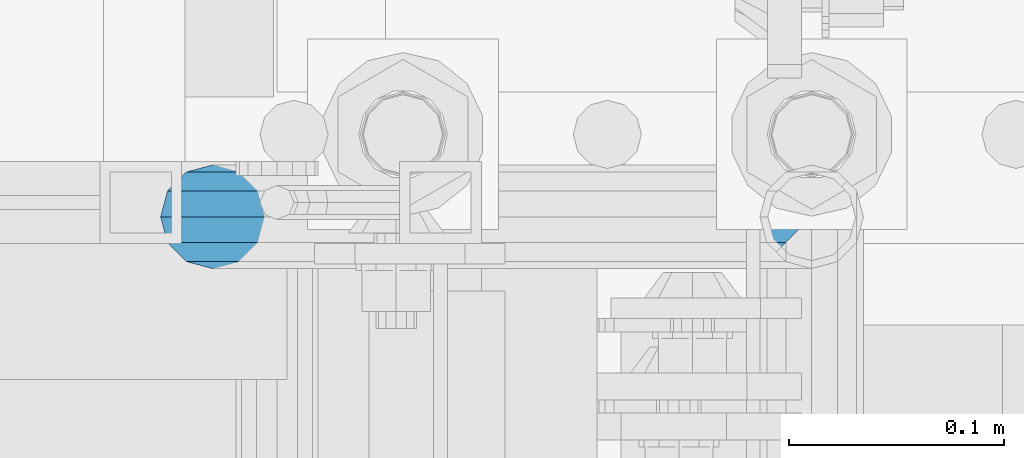
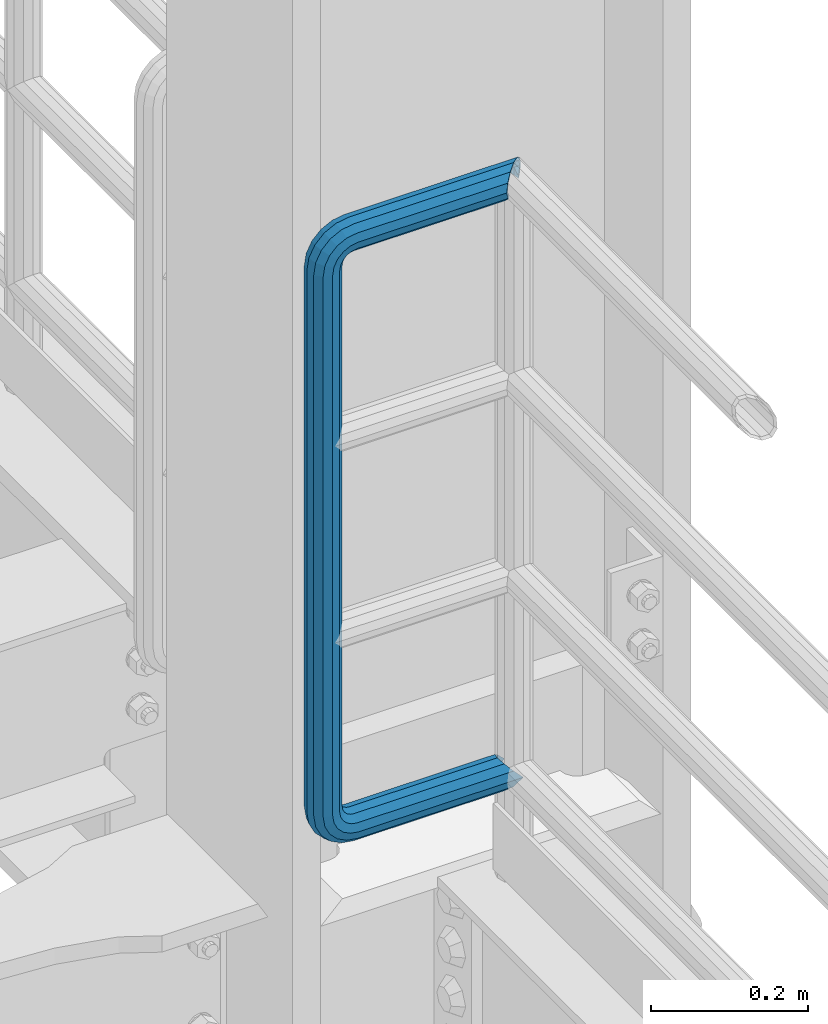
# One storey, part 992 of 1876: 1 beam, 1 element without a shape of its own.
"""IFC2X3 building model written with IfcOpenShell, lengths in millimetres."""

from ifc_helpers import new_model, si_unit, frame, origin_with_axes, place, context, subcontext, project, spatial, faceted_brep, material, type_object, element, aggregate, save


model = new_model("IFC2X3")

# Units and contexts
model_context = context("Model", 3, precision=1e-05, world=origin_with_axes())
body_context = subcontext(model_context, "Body", "Model", "MODEL_VIEW")
ifc_project = project(units=[si_unit("LENGTHUNIT", "METRE", prefix="MILLI"), si_unit("AREAUNIT", "SQUARE_METRE"), si_unit("VOLUMEUNIT", "CUBIC_METRE"), si_unit("MASSUNIT", "GRAM", prefix="KILO"), si_unit("TIMEUNIT", "SECOND"), si_unit("PLANEANGLEUNIT", "RADIAN"), si_unit("SOLIDANGLEUNIT", "STERADIAN"), si_unit("THERMODYNAMICTEMPERATUREUNIT", "DEGREE_CELSIUS"), si_unit("LUMINOUSINTENSITYUNIT", "LUMEN")], contexts=[model_context])

# Site, building, storey
site_placement = place(None, origin_with_axes())
site = spatial("IfcSite", under=ifc_project, at=site_placement, CompositionType="ELEMENT")
building_placement = place(site_placement, origin_with_axes())
building = spatial("IfcBuilding", under=site, at=building_placement, Name="Undefined", CompositionType="ELEMENT")
storey_placement = place(building_placement, origin_with_axes())
storey = spatial("IfcBuildingStorey", under=building, at=storey_placement, Name="Undefined", CompositionType="ELEMENT", Elevation=0.0)

# Assembly, beam
assembly_placement = place(storey_placement, origin_with_axes())
assembly = element("IfcElementAssembly", 1, at=assembly_placement, inside=storey, Name="RAIL", AssemblyPlace="NOTDEFINED", PredefinedType="RIGID_FRAME")
ifc_material = material()
beam_type = type_object("IfcBeamType", Name="PIPE1-1/2SCH40", PredefinedType="NOTDEFINED")
beam_placement = place(assembly_placement, frame((7620.0, -4788.2175, 19059.525), z_axis=(0.0, 0.0, 1.0), x_axis=(-1.0, 0.0, 0.0)))
beam = element("IfcBeam", 2, at=beam_placement, type_object=beam_type, material=ifc_material, Name="RAIL", ObjectType="PIPE1-1/2SCH40", context=body_context, shape_type="Brep", body=[
    faceted_brep([(16.4810964966631, 16.4810964966564, -11.4500249345219), (16.481099754581, 16.4810997545774, -16.4810932387409), (20.8971929933249, 12.0650000000005, -20.8971929933177), (20.8971929933249, 12.0650000000005, -15.8661214311796), (0.0, -24.1299999999992, 0.0), (12.0650000000014, -20.8971929933186, 0.0), (12.0650000000064, -20.8971929933177, -12.0649999999987), (-12.0650000000096, -20.8971929933177, -12.0649999999987), (-12.0649999999986, -20.8971929933186, 0.0), (-16.481093238739, -16.4810932387427, -16.4810997545756), (-16.4810964966554, -16.4810964966618, -11.4500249345183), (-15.2545715621367, -17.7076214311801, -10.2235000000001), (-12.5151929933171, -20.4470000000001, 0.0), (12.5151929933249, -20.4470000000001, 0.0), (20.8971929933249, -12.0650000000005, -15.8661214311796), (20.8971929933249, -12.0650000000005, -20.8971929933177), (15.2545715621445, -17.7076214311801, -10.2235000000001), (24.1300000000063, 0.0, -20.4470000000001), (24.1300000000063, 0.0, -24.130000000001), (21.3906214311868, -10.2235000000001, -17.7076214311819), (21.3906214311868, 10.2235000000001, -17.7076214311819), (1.20714750983051e-12, 24.1299999999974, -914.399963378906), (12.0650000000014, 20.8971929933159, -926.464963378905), (12.0650000000014, 20.8971929933177, -902.334963378908), (12.0650000000014, -20.8971929933195, -902.334963378908), (12.0650000000014, -20.8971929933195, -926.464963378905), (1.52133659548828e-12, -24.130000000001, -914.399963378906), (20.8971929933199, -12.0650000000023, -893.502770385589), (20.8971929933199, -12.0650000000005, -898.533841947723), (15.2545715621378, -17.7076214311819, -904.176463378906), (12.5151929933181, -20.4470000000019, -914.399963378906), (15.2545715621376, -17.7076214311819, -924.623463378906), (20.8971929933199, -12.0650000000005, -930.26608481009), (20.8971929933199, -12.0650000000023, -935.297156372224), (24.1300000000014, -1.81898940354586e-12, -934.846963378906), (24.1300000000014, -1.81898940354586e-12, -938.529963378907), (21.3906214311813, -10.2235000000019, -932.107584810088), (21.3906214311823, 10.2234999999982, -932.107584810088), (20.8971929933199, 12.0650000000005, -930.266084810086), (20.8971929933199, 12.0649999999987, -935.297156372224), (15.2545715621413, 17.7076214311783, -924.623463378906), (12.5151929933216, 20.4469999999983, -914.399963378906), (15.2545715621411, 17.7076214311783, -904.176463378906), (20.8971929933199, 12.0650000000005, -898.533841947727), (20.8971929933199, 12.0649999999987, -893.502770385589), (21.3906214311822, 10.2234999999982, -896.692341947724), (24.1300000000014, 0.0, -893.952963378906), (24.1300000000014, 0.0, -890.269963378905), (21.3906214311814, -10.2235000000019, -896.692341947724), (241.299995422363, -20.8971929933177, 12.0649999999987), (241.299995422363, -24.1299999999992, 0.0), (253.073542436527, -24.1299999999992, -1.86474665447167), (256.801832473661, -20.8971929933177, 9.60975021462946), (241.299995422363, -12.0650000000005, 20.8971929933177), (259.531130206197, -12.0650000000005, 18.0096649141014), (241.299995422363, 0.0, 24.130000000001), (260.530122510796, 0.0, 21.084247083727), (241.299995422363, 12.0650000000005, 20.8971929933177), (259.531130206197, 12.0650000000005, 18.0096649141014), (241.299995422363, 20.8971929933177, 12.0649999999987), (256.801832473661, 20.8971929933177, 9.60975021462946), (241.299995422363, 24.1299999999992, 0.0), (253.073542436527, 24.1299999999992, -1.86474665447167), (241.299995422363, 20.8971929933177, -12.0649999999987), (249.345252399393, 20.8971929933177, -13.3392435235728), (241.299995422363, 12.0650000000005, -20.8971929933177), (246.615954666858, 12.0650000000005, -21.7391582230448), (241.299995422363, 0.0, -24.130000000001), (245.616962362259, 0.0, -24.8137403926739), (241.299995422363, -12.0650000000005, -20.8971929933177), (246.615954666858, -12.0650000000005, -21.7391582230448), (241.299995422363, -20.8971929933177, -12.0649999999987), (249.345252399393, -20.8971929933177, -13.3392435235728), (267.334993896485, 20.8971929933177, -38.0999984741211), (279.399993896485, 24.1299999999992, -38.0999984741211), (279.399993896484, 24.1299999999992, -876.299964904785), (267.334993896484, 20.8971929933177, -876.299964904785), (291.464993896486, 20.8971929933177, -38.0999984741211), (291.464993896484, 20.8971929933177, -876.299964904785), (300.297186889804, 12.0650000000005, -38.0999984741211), (300.297186889803, 12.0650000000005, -876.299964904785), (303.529993896486, 0.0, -38.0999984741211), (303.529993896484, 0.0, -876.299964904785), (300.297186889804, -12.0650000000005, -38.0999984741211), (300.297186889803, -12.0650000000005, -876.299964904785), (291.464993896486, -20.8971929933177, -38.0999984741211), (291.464993896484, -20.8971929933177, -876.299964904785), (279.399993896484, -24.1299999999992, -38.0999984741211), (279.399993896484, -24.1299999999992, -876.299964904785), (267.334993896485, -20.8971929933177, -38.0999984741211), (267.334993896484, -20.8971929933177, -876.299964904785), (258.502800903167, -12.0650000000005, -38.0999984741211), (258.502800903166, -12.0650000000005, -876.299964904785), (255.269993896485, 0.0, -38.0999984741211), (255.269993896484, 0.0, -876.299964904785), (258.502800903167, 12.0650000000005, -38.0999984741211), (258.502800903166, 12.0650000000005, -876.299964904785), (257.660835673438, 12.0650000000005, -881.615924149282), (254.586253503809, 0.0, -880.616931844681), (257.660835673438, -12.0650000000005, -881.615924149282), (266.06075037291, -20.8971929933177, -884.345221881817), (277.535247242011, -24.130000000001, -888.073511918952), (289.009744111112, -20.8971929933195, -891.801801956084), (297.409658810584, -12.0650000000005, -894.531099688622), (300.484240980214, 0.0, -895.53009199322), (297.409658810584, 12.0650000000005, -894.531099688622), (289.009744111112, 20.8971929933177, -891.801801956084), (277.535247242011, 24.1299999999992, -888.073511918952), (266.06075037291, 20.8971929933177, -884.345221881817), (241.299995422364, -1.81898940354586e-12, -938.529963378911), (241.299995422364, -12.0650000000005, -935.297156372228), (241.299995422364, -20.8971929933195, -926.464963378909), (241.299995422363, -24.130000000001, -914.399963378906), (241.299995422363, -20.8971929933195, -902.334963378908), (241.299995422363, -12.0650000000005, -893.502770385589), (241.299995422363, 0.0, -890.269963378909), (241.299995422364, 20.8971929933177, -926.464963378909), (241.299995422364, 12.0649999999987, -935.297156372228), (241.299995422364, 24.1299999999992, -914.39996337891), (241.299995422363, 20.8971929933177, -902.334963378908), (241.299995422363, 12.0649999999987, -893.502770385589), (260.530122510801, 0.0, -935.484210462637), (259.531130206202, 12.0649999999987, -932.409628293008), (259.531130206201, -12.0650000000005, -932.409628293008), (256.801832473666, -20.8971929933195, -924.009713593536), (253.07354243653, -24.130000000001, -912.535216724435), (249.345252399395, -20.8971929933195, -901.060719855333), (246.615954666859, -12.0650000000005, -892.660805155861), (245.61696236226, 0.0, -889.586222986232), (246.615954666859, 12.0649999999987, -892.660805155861), (249.345252399395, 20.8971929933177, -901.060719855333), (253.07354243653, 24.1299999999992, -912.535216724435), (256.801832473666, 20.8971929933177, -924.009713593536), (275.977674493594, 12.0649999999987, -924.029695422345), (270.786241706733, 20.8971929933177, -916.884301193139), (277.877870775644, 0.0, -926.645091230272), (275.977674493608, -12.0650000000005, -924.029695422334), (270.786241706733, -20.8971929933195, -916.884301193139), (263.694612637823, -24.130000000001, -907.123511156005), (256.602983568912, -20.8971929933195, -897.362721118872), (251.411550782037, -12.0650000000005, -890.21732688968), (249.511354500001, 0.0, -887.601931081743), (251.411550782037, 12.0650000000005, -890.21732688968), (256.602983568912, 20.8971929933177, -897.362721118872), (263.694612637823, 24.1299999999992, -907.123511156005), (281.884331710718, 20.8971929933177, -905.786211189152), (272.123541673585, 24.1299999999992, -898.694582120243), (289.029725939912, 12.0650000000005, -910.977643976028), (291.645121747852, 0.0, -912.877840258065), (289.029725939912, -12.0650000000005, -910.977643976028), (281.884331710718, -20.8971929933195, -905.786211189152), (272.123541673585, -24.130000000001, -898.694582120243), (262.362751636451, -20.8971929933195, -891.602953051333), (255.217357407258, -12.0650000000005, -886.411520264461), (252.601961599318, 0.0, -884.511323982424), (255.217357407258, 12.0650000000005, -886.411520264461), (262.362751636451, 20.8971929933177, -891.602953051333), (266.060750372911, 20.8971929933177, -30.0547414970897), (257.660835673439, 12.0650000000005, -32.7840392296275), (277.535247242011, 24.1299999999992, -26.3264514599541), (289.009744111112, 20.8971929933177, -22.5981614228222), (297.409658810584, 12.0650000000005, -19.8688636902843), (300.484240980213, 0.0, -18.8698713856866), (297.409658810584, -12.0650000000005, -19.8688636902843), (289.009744111112, -20.8971929933177, -22.5981614228222), (277.535247242011, -24.1299999999992, -26.3264514599541), (266.060750372911, -20.8971929933177, -30.0547414970897), (257.660835673439, -12.0650000000005, -32.7840392296275), (254.58625350381, 0.0, -33.7830315342253), (255.217357407257, 12.0650000000005, -27.9884431144455), (252.601961599318, 0.0, -29.8886393964822), (262.362751636451, 20.8971929933177, -22.7970103275729), (272.123541673583, 24.1299999999992, -15.7053812586601), (281.884331710716, 20.8971929933177, -8.61375218975081), (289.029725939909, 12.0650000000005, -3.42231940287456), (291.645121747848, 0.0, -1.52212312084157), (289.029725939909, -12.0650000000005, -3.42231940287456), (281.884331710716, -20.8971929933177, -8.61375218975081), (272.123541673583, -24.1299999999992, -15.7053812586601), (262.362751636451, -20.8971929933177, -22.7970103275729), (255.217357407257, -12.0650000000005, -27.9884431144455), (249.511354500002, 0.0, -26.7980322971671), (251.411550782037, -12.0650000000005, -24.1826364892258), (251.411550782037, 12.0650000000005, -24.1826364892258), (256.602983568912, 20.8971929933177, -17.037242260034), (263.694612637822, 24.1299999999992, -7.27645222290084), (270.786241706732, 20.8971929933177, 2.48433781423228), (275.977674493607, 12.0650000000005, 9.62973204342416), (277.877870775642, 0.0, 12.2451278513654), (275.977674493607, -12.0650000000005, 9.62973204342416), (270.786241706732, -20.8971929933177, 2.48433781423228), (263.694612637822, -24.1299999999992, -7.27645222290084), (256.602983568912, -20.8971929933177, -17.037242260034), (20.8971929933232, 20.8971929933177, -12.0649999999987), (24.1300000000047, 24.1299999999992, 0.0), (20.8971929933232, 20.8971929933177, 12.0649999999987), (12.0650000000041, 12.0650000000005, 20.8971929933177), (-1.45519152283669e-11, 0.0, 24.130000000001), (-12.0649999999951, -12.0650000000005, 20.8971929933177), (-20.8971929933141, -20.8971929933177, 12.0649999999987), (-24.1299999999956, -24.1299999999992, 0.0), (-20.8971929933141, -20.8971929933177, -12.0649999999987), (-17.7076214311755, -17.7076214311801, -10.2235000000001), (-20.4469999999956, -20.4470000000001, 0.0), (-17.7076214311755, -17.7076214311801, 10.2235000000001), (241.299995422363, -17.7076214311801, 10.2235000000001), (241.299995422363, -20.4470000000001, 0.0), (241.299995422363, -17.7076214311801, -10.2235000000001), (241.299995422363, -10.2235000000001, -17.7076214311819), (241.299995422363, 0.0, -20.4470000000001), (241.299995422363, 0.0, 20.4470000000001), (241.299995422363, -10.2235000000001, 17.7076214311819), (-10.2234999999955, -10.2235000000001, 17.7076214311819), (-1.45519152283669e-11, 0.0, 20.4470000000001), (241.299995422363, 10.2235000000001, 17.7076214311819), (10.2235000000046, 10.2235000000001, 17.7076214311819), (241.299995422363, 17.7076214311801, 10.2235000000001), (17.7076214311846, 17.7076214311801, 10.2235000000001), (241.299995422363, 20.4470000000001, 0.0), (20.4470000000047, 20.4470000000001, 0.0), (241.299995422363, 17.7076214311801, -10.2235000000001), (17.7076214311846, 17.7076214311801, -10.2235000000001), (241.299995422363, 10.2235000000001, -17.7076214311819), (258.545498388721, -10.2235000000001, 14.9762020957387), (256.23277767852, -17.7076214311801, 7.85837963987069), (253.073542436527, -20.4470000000001, -1.86474665447167), (249.914307194535, -17.7076214311801, -11.5878729488177), (247.601586484334, -10.2235000000001, -18.7056954046857), (246.755071952542, 0.0, -21.31099924316), (247.601586484334, 10.2235000000001, -18.7056954046857), (249.914307194535, 17.7076214311801, -11.5878729488177), (253.073542436527, 20.4470000000001, -1.86474665447167), (256.23277767852, 17.7076214311801, 7.85837963987069), (258.545498388721, 10.2235000000001, 14.9762020957387), (259.392012920513, 0.0, 17.5815059342131), (275.713057691449, 0.0, 9.26551826108334), (274.10289136825, -10.2235000000001, 7.04931444488102), (274.10289136825, 10.2235000000001, 7.04931444488102), (269.703835164635, 17.7076214311801, 0.994533019089431), (263.694612637822, 20.4470000000001, -7.27645222290084), (257.685390111009, 17.7076214311801, -15.5474374648911), (253.286333907394, 10.2235000000001, -21.6022188906827), (251.676167584195, 0.0, -23.818422706885), (253.286333907394, -10.2235000000001, -21.6022188906827), (257.685390111009, -17.7076214311801, -15.5474374648911), (263.694612637822, -20.4470000000001, -7.27645222290084), (269.703835164635, -17.7076214311801, 0.994533019089431), (286.449308341364, -10.2235000000001, -5.29710252823133), (280.394526915574, -17.7076214311801, -9.69615873184739), (288.665512157566, 0.0, -3.68693620503473), (286.449308341364, 10.2235000000001, -5.29710252823133), (280.394526915574, 17.7076214311801, -9.69615873184739), (272.123541673583, 20.4470000000001, -15.7053812586601), (263.852556431592, 17.7076214311801, -21.7146037854764), (257.797775005802, 10.2235000000001, -26.1136599890888), (255.581571189601, 0.0, -27.723826312289), (257.797775005802, -10.2235000000001, -26.1136599890888), (263.852556431592, -17.7076214311801, -21.7146037854764), (272.123541673583, -20.4470000000001, -15.7053812586601), (287.258373536355, -17.7076214311801, -23.1672162179639), (277.535247242011, -20.4470000000001, -26.3264514599541), (294.376195992223, -10.2235000000001, -20.8544955077632), (296.981499830698, 0.0, -20.00798097597), (294.376195992223, 10.2235000000001, -20.8544955077632), (287.258373536355, 17.7076214311801, -23.1672162179639), (277.535247242011, 20.4470000000001, -26.3264514599541), (267.812120947668, 17.7076214311801, -29.485686701948), (260.6942984918, 10.2235000000001, -31.7984074121487), (258.088994653325, 0.0, -32.6449219439419), (260.6942984918, -10.2235000000001, -31.7984074121487), (267.812120947668, -17.7076214311801, -29.485686701948), (279.399993896484, -20.4470000000001, -38.0999984741211), (269.176493896485, -17.7076214311801, -38.0999984741211), (289.623493896486, -17.7076214311801, -38.0999984741211), (297.107615327666, -10.2235000000001, -38.0999984741211), (299.846993896486, 0.0, -38.0999984741211), (297.107615327666, 10.2235000000001, -38.0999984741211), (289.623493896486, 17.7076214311801, -38.0999984741211), (279.399993896485, 20.4470000000001, -38.0999984741211), (269.176493896485, 17.7076214311801, -38.0999984741211), (261.692372465305, 10.2235000000001, -38.0999984741211), (258.952993896485, 0.0, -38.0999984741211), (261.692372465305, -10.2235000000001, -38.0999984741211), (269.176493896484, -17.7076214311801, -876.299964904785), (261.692372465304, -10.2235000000001, -876.299964904785), (258.952993896484, 0.0, -876.299964904785), (261.692372465304, 10.2235000000001, -876.299964904785), (269.176493896484, 17.7076214311801, -876.299964904785), (279.399993896484, 20.4470000000001, -876.299964904785), (289.623493896484, 17.7076214311801, -876.299964904785), (297.107615327665, 10.2235000000001, -876.299964904785), (299.846993896484, 0.0, -876.299964904785), (297.107615327665, -10.2235000000001, -876.299964904785), (289.623493896484, -17.7076214311801, -876.299964904785), (279.399993896484, -20.4470000000001, -876.299964904785), (277.535247242011, -20.4470000000001, -888.073511918952), (267.812120947667, -17.7076214311801, -884.914276676958), (260.694298491799, -10.2235000000001, -882.601555966758), (258.088994653324, 0.0, -881.755041434964), (260.694298491799, 10.2235000000001, -882.601555966758), (267.812120947668, 17.7076214311801, -884.914276676958), (277.535247242011, 20.4470000000001, -888.073511918952), (287.258373536355, 17.7076214311801, -891.232747160942), (294.376195992223, 10.2235000000001, -893.545467871143), (296.981499830699, 0.0, -894.391982402936), (294.376195992223, -10.2235000000001, -893.545467871143), (287.258373536355, -17.7076214311801, -891.232747160942), (280.394526915577, -17.7076214311801, -904.703804647055), (272.123541673585, -20.4470000000001, -898.694582120243), (286.449308341367, -10.2235000000001, -909.102860850671), (288.665512157569, 0.0, -910.713027173868), (286.449308341367, 10.2235000000001, -909.102860850671), (280.394526915577, 17.7076214311801, -904.703804647055), (272.123541673585, 20.4470000000001, -898.694582120243), (263.852556431593, 17.7076214311801, -892.68535959343), (257.797775005802, 10.2235000000001, -888.286303389817), (255.581571189601, 0.0, -886.676137066617), (257.797775005802, -10.2235000000001, -888.286303389817), (263.852556431593, -17.7076214311801, -892.68535959343), (263.694612637823, -20.4470000000001, -907.123511156005), (257.685390111009, -17.7076214311801, -898.852525914015), (269.703835164636, -17.7076214311801, -915.394496397999), (274.102891368238, -10.2235000000001, -921.449277823798), (275.71305769145, 0.0, -923.66548163999), (274.102891368251, 10.2235000000001, -921.449277823787), (269.703835164636, 17.7076214311801, -915.394496397999), (263.694612637823, 20.4470000000001, -907.123511156005), (257.685390111009, 17.7076214311801, -898.852525914015), (253.286333907394, 10.2235000000001, -892.797744488227), (251.676167584195, 0.0, -890.581540672025), (253.286333907394, -10.2235000000001, -892.797744488227), (249.914307194537, -17.7076214311801, -902.812090430092), (247.601586484335, -10.2235000000001, -895.694267974224), (253.07354243653, -20.4470000000001, -912.535216724435), (256.232777678524, -17.7076214311819, -922.258343018777), (258.545498388725, -10.2235000000001, -929.376165474645), (259.392012920517, 0.0, -931.981469313119), (258.545498388725, 10.2235000000001, -929.376165474645), (256.232777678524, 17.7076214311801, -922.258343018777), (253.07354243653, 20.4470000000001, -912.535216724435), (249.914307194537, 17.7076214311801, -902.812090430092), (247.601586484335, 10.2235000000001, -895.694267974224), (246.755071952543, 0.0, -893.088964135746), (241.299995422363, -10.2235000000001, -896.692341947728), (241.299995422363, 0.0, -893.95296337891), (241.299995422363, -17.7076214311819, -904.17646337891), (241.299995422363, -20.4470000000001, -914.399963378906), (241.299995422364, -17.7076214311819, -924.62346337891), (241.299995422364, -10.2235000000001, -932.107584810088), (241.299995422364, -1.81898940354586e-12, -934.84696337891), (241.299995422364, 10.2234999999982, -932.107584810088), (241.299995422364, 17.7076214311801, -924.62346337891), (241.299995422364, 20.4470000000001, -914.39996337891), (241.299995422363, 17.7076214311801, -904.17646337891), (241.299995422363, 10.2235000000001, -896.692341947728)], [[[0, 1, 2, 3]], [[4, 5, 6]], [[7, 8, 4]], [[9, 10, 11, 12, 8, 7]], [[13, 5, 4, 8, 12]], [[14, 15, 6, 5, 13, 16]], [[17, 18, 15, 14, 19]], [[20, 3, 2, 18, 17]], [[21, 22, 23]], [[24, 25, 26]], [[27, 28, 29, 30, 31, 32, 33, 25, 24]], [[34, 35, 33, 32, 36]], [[37, 38, 39, 35, 34]], [[23, 22, 39, 38, 40, 41, 42, 43, 44]], [[44, 43, 45, 46, 47]], [[47, 46, 48, 28, 27]], [[49, 50, 51, 52]], [[53, 49, 52, 54]], [[55, 53, 54, 56]], [[57, 55, 56, 58]], [[59, 57, 58, 60]], [[61, 59, 60, 62]], [[63, 61, 62, 64]], [[65, 63, 64, 66]], [[67, 65, 66, 68]], [[69, 67, 68, 70]], [[71, 69, 70, 72]], [[73, 74, 75, 76]], [[74, 77, 78, 75]], [[77, 79, 80, 78]], [[79, 81, 82, 80]], [[81, 83, 84, 82]], [[83, 85, 86, 84]], [[85, 87, 88, 86]], [[87, 89, 90, 88]], [[89, 91, 92, 90]], [[91, 93, 94, 92]], [[93, 95, 96, 94]], [[94, 96, 97, 98]], [[92, 94, 98, 99]], [[90, 92, 99, 100]], [[88, 90, 100, 101]], [[86, 88, 101, 102]], [[84, 86, 102, 103]], [[82, 84, 103, 104]], [[80, 82, 104, 105]], [[78, 80, 105, 106]], [[75, 78, 106, 107]], [[76, 75, 107, 108]], [[109, 110, 33, 35]], [[110, 111, 25, 33]], [[111, 112, 26, 25]], [[112, 113, 24, 26]], [[113, 114, 27, 24]], [[114, 115, 47, 27]], [[116, 117, 39, 22]], [[118, 116, 22, 21]], [[119, 118, 21, 23]], [[120, 119, 23, 44]], [[115, 120, 44, 47]], [[117, 109, 35, 39]], [[121, 109, 117, 122]], [[123, 110, 109, 121]], [[124, 111, 110, 123]], [[125, 112, 111, 124]], [[126, 113, 112, 125]], [[127, 114, 113, 126]], [[128, 115, 114, 127]], [[129, 120, 115, 128]], [[130, 119, 120, 129]], [[131, 118, 119, 130]], [[132, 116, 118, 131]], [[122, 117, 116, 132]], [[133, 122, 132, 134]], [[135, 121, 122, 133]], [[136, 123, 121, 135]], [[137, 124, 123, 136]], [[138, 125, 124, 137]], [[139, 126, 125, 138]], [[140, 127, 126, 139]], [[141, 128, 127, 140]], [[142, 129, 128, 141]], [[143, 130, 129, 142]], [[144, 131, 130, 143]], [[134, 132, 131, 144]], [[145, 134, 144, 146]], [[147, 133, 134, 145]], [[148, 135, 133, 147]], [[149, 136, 135, 148]], [[150, 137, 136, 149]], [[151, 138, 137, 150]], [[152, 139, 138, 151]], [[153, 140, 139, 152]], [[154, 141, 140, 153]], [[155, 142, 141, 154]], [[156, 143, 142, 155]], [[146, 144, 143, 156]], [[107, 146, 156, 108]], [[106, 145, 146, 107]], [[105, 147, 145, 106]], [[104, 148, 147, 105]], [[103, 149, 148, 104]], [[102, 150, 149, 103]], [[101, 151, 150, 102]], [[100, 152, 151, 101]], [[99, 153, 152, 100]], [[98, 154, 153, 99]], [[97, 155, 154, 98]], [[108, 156, 155, 97]], [[96, 76, 108, 97]], [[95, 73, 76, 96]], [[157, 73, 95, 158]], [[159, 74, 73, 157]], [[160, 77, 74, 159]], [[161, 79, 77, 160]], [[162, 81, 79, 161]], [[163, 83, 81, 162]], [[164, 85, 83, 163]], [[165, 87, 85, 164]], [[166, 89, 87, 165]], [[167, 91, 89, 166]], [[168, 93, 91, 167]], [[158, 95, 93, 168]], [[169, 158, 168, 170]], [[171, 157, 158, 169]], [[172, 159, 157, 171]], [[173, 160, 159, 172]], [[174, 161, 160, 173]], [[175, 162, 161, 174]], [[176, 163, 162, 175]], [[177, 164, 163, 176]], [[178, 165, 164, 177]], [[179, 166, 165, 178]], [[180, 167, 166, 179]], [[170, 168, 167, 180]], [[181, 170, 180, 182]], [[183, 169, 170, 181]], [[184, 171, 169, 183]], [[185, 172, 171, 184]], [[186, 173, 172, 185]], [[187, 174, 173, 186]], [[188, 175, 174, 187]], [[189, 176, 175, 188]], [[190, 177, 176, 189]], [[191, 178, 177, 190]], [[192, 179, 178, 191]], [[182, 180, 179, 192]], [[70, 182, 192, 72]], [[68, 181, 182, 70]], [[66, 183, 181, 68]], [[64, 184, 183, 66]], [[62, 185, 184, 64]], [[60, 186, 185, 62]], [[58, 187, 186, 60]], [[56, 188, 187, 58]], [[54, 189, 188, 56]], [[52, 190, 189, 54]], [[51, 191, 190, 52]], [[72, 192, 191, 51]], [[50, 71, 72, 51]], [[71, 50, 4, 6]], [[69, 71, 6, 15]], [[67, 69, 15, 18]], [[65, 67, 18, 2]], [[193, 63, 65, 2, 1]], [[61, 63, 193, 194]], [[59, 61, 194, 195]], [[57, 59, 195, 196]], [[55, 57, 196, 197]], [[53, 55, 197, 198]], [[49, 53, 198, 199]], [[4, 50, 49, 199, 200]], [[200, 201, 7, 4]], [[201, 9, 7]], [[202, 11, 10]], [[202, 203, 12, 11]], [[203, 204, 205, 206, 13, 12]], [[206, 207, 16, 13]], [[16, 207, 208, 19, 14]], [[208, 209, 17, 19]], [[210, 211, 212, 213]], [[214, 210, 213, 215]], [[216, 214, 215, 217]], [[218, 216, 217, 219]], [[220, 218, 219, 221]], [[222, 220, 221, 0, 3, 20]], [[209, 222, 20, 17]], [[221, 219, 217, 215, 213, 212, 204, 203, 202, 10, 9, 201, 200, 199, 198, 197, 196, 195, 194, 193, 1, 0]], [[211, 205, 204, 212]], [[205, 211, 223, 224]], [[206, 205, 224, 225]], [[207, 206, 225, 226]], [[208, 207, 226, 227]], [[209, 208, 227, 228]], [[222, 209, 228, 229]], [[220, 222, 229, 230]], [[218, 220, 230, 231]], [[216, 218, 231, 232]], [[214, 216, 232, 233]], [[210, 214, 233, 234]], [[211, 210, 234, 223]], [[234, 235, 236, 223]], [[233, 237, 235, 234]], [[232, 238, 237, 233]], [[231, 239, 238, 232]], [[230, 240, 239, 231]], [[229, 241, 240, 230]], [[228, 242, 241, 229]], [[227, 243, 242, 228]], [[226, 244, 243, 227]], [[225, 245, 244, 226]], [[224, 246, 245, 225]], [[223, 236, 246, 224]], [[236, 247, 248, 246]], [[235, 249, 247, 236]], [[237, 250, 249, 235]], [[238, 251, 250, 237]], [[239, 252, 251, 238]], [[240, 253, 252, 239]], [[241, 254, 253, 240]], [[242, 255, 254, 241]], [[243, 256, 255, 242]], [[244, 257, 256, 243]], [[245, 258, 257, 244]], [[246, 248, 258, 245]], [[248, 259, 260, 258]], [[247, 261, 259, 248]], [[249, 262, 261, 247]], [[250, 263, 262, 249]], [[251, 264, 263, 250]], [[252, 265, 264, 251]], [[253, 266, 265, 252]], [[254, 267, 266, 253]], [[255, 268, 267, 254]], [[256, 269, 268, 255]], [[257, 270, 269, 256]], [[258, 260, 270, 257]], [[260, 271, 272, 270]], [[259, 273, 271, 260]], [[261, 274, 273, 259]], [[262, 275, 274, 261]], [[263, 276, 275, 262]], [[264, 277, 276, 263]], [[265, 278, 277, 264]], [[266, 279, 278, 265]], [[267, 280, 279, 266]], [[268, 281, 280, 267]], [[269, 282, 281, 268]], [[270, 272, 282, 269]], [[282, 272, 283, 284]], [[281, 282, 284, 285]], [[280, 281, 285, 286]], [[279, 280, 286, 287]], [[278, 279, 287, 288]], [[277, 278, 288, 289]], [[276, 277, 289, 290]], [[275, 276, 290, 291]], [[274, 275, 291, 292]], [[273, 274, 292, 293]], [[271, 273, 293, 294]], [[272, 271, 294, 283]], [[283, 294, 295, 296]], [[284, 283, 296, 297]], [[285, 284, 297, 298]], [[286, 285, 298, 299]], [[287, 286, 299, 300]], [[288, 287, 300, 301]], [[289, 288, 301, 302]], [[290, 289, 302, 303]], [[291, 290, 303, 304]], [[292, 291, 304, 305]], [[293, 292, 305, 306]], [[294, 293, 306, 295]], [[306, 307, 308, 295]], [[305, 309, 307, 306]], [[304, 310, 309, 305]], [[303, 311, 310, 304]], [[302, 312, 311, 303]], [[301, 313, 312, 302]], [[300, 314, 313, 301]], [[299, 315, 314, 300]], [[298, 316, 315, 299]], [[297, 317, 316, 298]], [[296, 318, 317, 297]], [[295, 308, 318, 296]], [[308, 319, 320, 318]], [[307, 321, 319, 308]], [[309, 322, 321, 307]], [[310, 323, 322, 309]], [[311, 324, 323, 310]], [[312, 325, 324, 311]], [[313, 326, 325, 312]], [[314, 327, 326, 313]], [[315, 328, 327, 314]], [[316, 329, 328, 315]], [[317, 330, 329, 316]], [[318, 320, 330, 317]], [[320, 331, 332, 330]], [[319, 333, 331, 320]], [[321, 334, 333, 319]], [[322, 335, 334, 321]], [[323, 336, 335, 322]], [[324, 337, 336, 323]], [[325, 338, 337, 324]], [[326, 339, 338, 325]], [[327, 340, 339, 326]], [[328, 341, 340, 327]], [[329, 342, 341, 328]], [[330, 332, 342, 329]], [[332, 343, 344, 342]], [[331, 345, 343, 332]], [[333, 346, 345, 331]], [[334, 347, 346, 333]], [[335, 348, 347, 334]], [[336, 349, 348, 335]], [[337, 350, 349, 336]], [[338, 351, 350, 337]], [[339, 352, 351, 338]], [[340, 353, 352, 339]], [[341, 354, 353, 340]], [[342, 344, 354, 341]], [[354, 344, 46, 45]], [[42, 353, 354, 45, 43]], [[352, 353, 42, 41]], [[351, 352, 41, 40]], [[350, 351, 40, 38, 37]], [[349, 350, 37, 34]], [[348, 349, 34, 36]], [[31, 347, 348, 36, 32]], [[346, 347, 31, 30]], [[345, 346, 30, 29]], [[343, 345, 29, 28, 48]], [[344, 343, 48, 46]]]),
])
aggregate(assembly, [beam])

save(model, "model.ifc")
